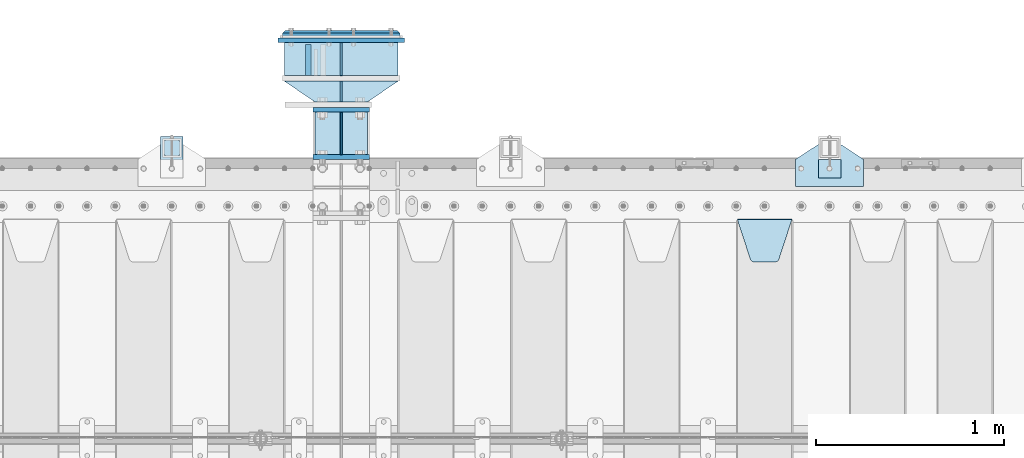
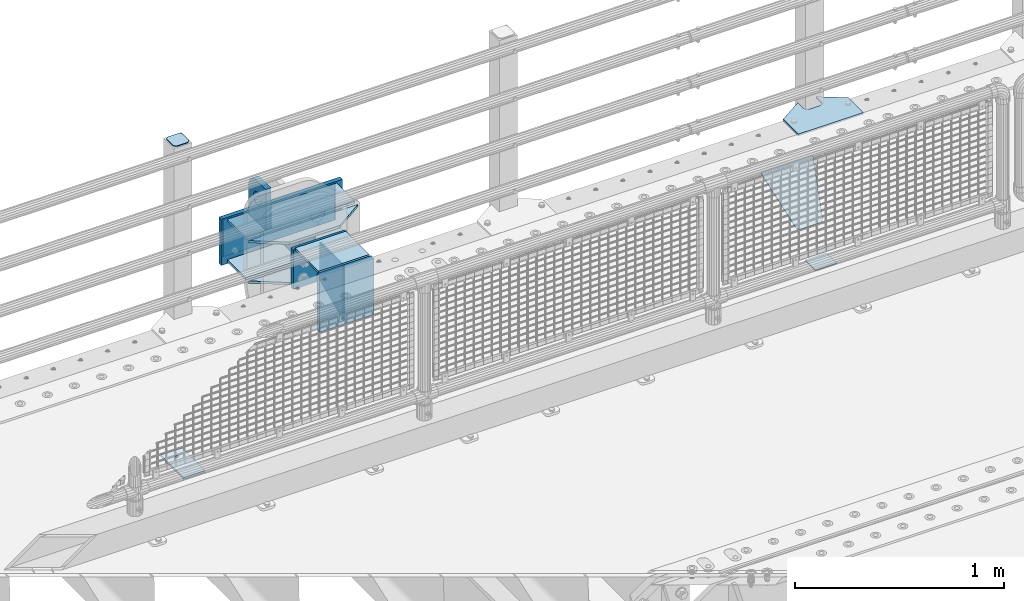
# One storey, part 222 of 247: 18 plates.
"""IFC2X3 building model written with IfcOpenShell, lengths in millimetres."""

from ifc_helpers import new_model, si_unit, frame, origin_with_axes, place, context, subcontext, project, spatial, faceted_brep, material, type_object, element, save


model = new_model("IFC2X3")

# Units and contexts
model_context = context("Model", 3, precision=1e-05, world=origin_with_axes())
body_context = subcontext(model_context, "Body", "Model", "MODEL_VIEW")
ifc_project = project(units=[si_unit("LENGTHUNIT", "METRE", prefix="MILLI"), si_unit("AREAUNIT", "SQUARE_METRE"), si_unit("VOLUMEUNIT", "CUBIC_METRE"), si_unit("MASSUNIT", "GRAM", prefix="KILO"), si_unit("TIMEUNIT", "SECOND"), si_unit("PLANEANGLEUNIT", "RADIAN"), si_unit("SOLIDANGLEUNIT", "STERADIAN"), si_unit("THERMODYNAMICTEMPERATUREUNIT", "DEGREE_CELSIUS"), si_unit("LUMINOUSINTENSITYUNIT", "LUMEN")], contexts=[model_context])

# Site, building, storey
site_placement = place(None, origin_with_axes())
site = spatial("IfcSite", under=ifc_project, at=site_placement, CompositionType="ELEMENT")
building_placement = place(site_placement, origin_with_axes())
building = spatial("IfcBuilding", under=site, at=building_placement, Name="Standard", CompositionType="ELEMENT")
storey_placement = place(building_placement, origin_with_axes())
storey = spatial("IfcBuildingStorey", under=building, at=storey_placement, Name="Undefined", CompositionType="ELEMENT", Elevation=0.0)

# Plates
ifc_material_1 = material(Name="STEEL/S355N")
plate_type_1 = type_object("IfcPlateType", PredefinedType="NOTDEFINED")
plate_1_placement = place(storey_placement, frame((12099.9999999856, 9162.50000001511, -340.000018222004), z_axis=(0.0, 0.0, 1.0), x_axis=(1.0, 0.0, 0.0)))
element("IfcPlate", 1, at=plate_1_placement, inside=storey, type_object=plate_type_1, material=ifc_material_1, context=body_context, shape_type="Brep", body=[
    faceted_brep([(0.0, -12.5, 0.0), (0.0, -12.5, 330.0), (0.0, 12.5, 330.0), (0.0, 12.5, 0.0), (300.0, -12.5, 330.0), (300.0, 12.5, 330.0), (300.0, -12.5, 0.0), (300.0, 12.5, 0.0)], [[[0, 1, 2, 3]], [[1, 4, 5, 2]], [[4, 6, 7, 5]], [[6, 0, 3, 7]], [[5, 7, 3, 2]], [[6, 4, 1, 0]]]),
])
plate_type_2 = type_object("IfcPlateType", PredefinedType="NOTDEFINED")
plate_2_placement = place(storey_placement, frame((12249.9999999856, 9175.00000001511, -336.000018222004), z_axis=(0.0, 1.0, 0.0), x_axis=(0.0, 0.0, 1.0)))
element("IfcPlate", 2, at=plate_2_placement, inside=storey, type_object=plate_type_2, material=ifc_material_1, context=body_context, shape_type="Brep", body=[
    faceted_brep([(9.04219632502645e-09, -5.00000000143385, -2.89173840428703e-09), (100.0, -5.0, 225.0), (100.0, 5.0, 225.0), (7.66340235713869e-09, 4.99999999856618, -2.89173840428703e-09), (322.0, -5.0, 225.0), (322.0, 5.0, 225.0), (322.0, -5.0, 0.0), (322.0, 5.0, 0.0)], [[[0, 1, 2, 3]], [[1, 4, 5, 2]], [[4, 6, 7, 5]], [[6, 0, 3, 7]], [[5, 7, 3, 2]], [[6, 4, 1, 0]]]),
])
plate_type_3 = type_object("IfcPlateType", PredefinedType="NOTDEFINED")
plate_3_placement = place(storey_placement, frame((12074.4999999856, 9595.00000001511, -1.8222003518531e-05), z_axis=(0.0, 1.0, 0.0), x_axis=(0.0, 0.0, 1.0)))
element("IfcPlate", 3, at=plate_3_placement, inside=storey, type_object=plate_type_3, material=ifc_material_1, context=body_context, shape_type="Brep", body=[
    faceted_brep([(125.840713002492, 15.0, 114.183542702918), (125.840713002492, -15.0, 114.183542702918), (113.837049096098, -15.0, 106.162950903903), (113.837049096098, 15.0, 106.162950903903), (105.816457297082, -15.0, 94.1592869975084), (105.816457297082, 15.0, 94.1592869975084), (103.0, -15.0, 80.0), (103.0, 15.0, 80.0), (105.816457297082, -15.0, 65.8407130024916), (105.816457297082, 15.0, 65.8407130024916), (113.837049096098, -15.0, 53.837049096097), (113.837049096098, 15.0, 53.837049096097), (125.840713002492, -15.0, 45.8164572970818), (125.840713002492, 15.0, 45.8164572970818), (140.0, -15.0, 43.0), (140.0, 15.0, 43.0), (154.159286997508, -15.0, 45.8164572970818), (154.159286997508, 15.0, 45.8164572970818), (166.162950903902, -15.0, 53.837049096097), (166.162950903902, 15.0, 53.837049096097), (174.183542702918, -15.0, 65.8407130024916), (174.183542702918, 15.0, 65.8407130024916), (177.0, -15.0, 80.0), (177.0, 15.0, 80.0), (174.183542702918, -15.0, 94.1592869975084), (174.183542702918, 15.0, 94.1592869975084), (166.162950903902, -15.0, 106.162950903903), (166.162950903902, 15.0, 106.162950903903), (154.159286997508, -15.0, 114.183542702918), (154.159286997508, 15.0, 114.183542702918), (140.0, -15.0, 117.0), (140.0, 15.0, 117.0), (0.0, -15.0, 165.0), (170.0, -15.0, 165.0), (170.0, 15.0, 165.0), (0.0, 15.0, 165.0), (188.117333157176, -15.0, 162.614807840235), (188.117333157176, 15.0, 162.614807840235), (205.0, -15.0, 155.621778264911), (205.0, 15.0, 155.621778264911), (219.497474683058, -15.0, 144.497474683058), (219.497474683058, 15.0, 144.497474683058), (230.621778264911, -15.0, 130.0), (230.621778264911, 15.0, 130.0), (237.614807840235, -15.0, 113.117333157177), (237.614807840235, 15.0, 113.117333157177), (240.0, -15.0, 95.0), (240.0, 15.0, 95.0), (240.0, -15.0, 0.0), (240.0, 15.0, 0.0), (0.0, -15.0, 0.0), (0.0, 15.0, 0.0)], [[[0, 1, 2, 3]], [[3, 2, 4, 5]], [[5, 4, 6, 7]], [[7, 6, 8, 9]], [[9, 8, 10, 11]], [[11, 10, 12, 13]], [[13, 12, 14, 15]], [[15, 14, 16, 17]], [[17, 16, 18, 19]], [[19, 18, 20, 21]], [[21, 20, 22, 23]], [[23, 22, 24, 25]], [[25, 24, 26, 27]], [[27, 26, 28, 29]], [[29, 28, 30, 31]], [[31, 30, 1, 0]], [[32, 33, 34, 35]], [[33, 36, 37, 34]], [[36, 38, 39, 37]], [[38, 40, 41, 39]], [[40, 42, 43, 41]], [[42, 44, 45, 43]], [[44, 46, 47, 45]], [[46, 48, 49, 47]], [[48, 50, 51, 49]], [[34, 37, 39, 41, 43, 45, 47, 49, 51, 35], [3, 5, 7, 9, 11, 13, 15, 17, 19, 21, 23, 25, 27, 29, 31, 0]], [[50, 32, 35, 51]], [[48, 46, 44, 42, 40, 38, 36, 33, 32, 50], [26, 24, 22, 20, 18, 16, 14, 12, 10, 8, 6, 4, 2, 1, 30, 28]]]),
])
plate_type_4 = type_object("IfcPlateType", PredefinedType="NOTDEFINED")
plate_4_placement = place(storey_placement, frame((14355.0, 8831.76776695594, -1.767766952965), z_axis=(0.0, -0.707106781186548, -0.707106781186547), x_axis=(1.0, 0.0, 0.0)))
element("IfcPlate", 4, at=plate_4_placement, inside=storey, type_object=plate_type_4, material=ifc_material_1, context=body_context, shape_type="Brep", body=[
    faceted_brep([(0.0, -2.49999999999909, 0.0), (69.345504679477, -2.5, 300.17173142483), (69.345504679477, 2.50000000000091, 300.171731424831), (0.0, 2.5, -9.09494701772928e-13), (70.9274061199576, -2.5, 304.897442415399), (70.9274061199576, 2.50000000000091, 304.8974424154), (73.3818627772307, -2.49999999999909, 309.234538108527), (73.3818627772307, 2.5, 309.234538108526), (76.6187032999551, -2.5, 313.023683126102), (76.6187032999551, 2.50000000000091, 313.023683126102), (80.5190132704993, -2.49999999999909, 316.125672595371), (80.5190132704993, 2.50000000000091, 316.125672595372), (84.9395038596849, -2.49999999999909, 318.426546230476), (84.9395038596849, 2.5, 318.426546230475), (89.7177759439219, -2.5, 319.841774983274), (89.7177759439219, 2.50000000000091, 319.841774983275), (94.678286292652, -2.5, 320.319366455077), (94.678286292652, 2.50000000000091, 320.319366455077), (195.321713707348, -2.5, 320.319366455077), (195.321713707348, 2.50000000000091, 320.319366455077), (200.282224056078, -2.5, 319.841774983274), (200.282224056078, 2.50000000000091, 319.841774983275), (205.060496140315, -2.5, 318.426546230475), (205.060496140315, 2.5, 318.426546230474), (209.480986729501, -2.49999999999818, 316.12567259537), (209.480986729501, 2.50000000000091, 316.12567259537), (213.381296700045, -2.5, 313.023683126101), (213.381296700045, 2.50000000000091, 313.023683126101), (216.618137222769, -2.5, 309.234538108525), (216.618137222769, 2.5, 309.234538108525), (219.072593880042, -2.49999999999909, 304.897442415398), (219.072593880042, 2.5, 304.897442415398), (220.654495320523, -2.5, 300.17173142483), (220.654495320523, 2.50000000000091, 300.171731424831), (290.0, -2.49999999999909, 0.0), (290.0, 2.5, -9.09494701772928e-13)], [[[0, 1, 2, 3]], [[1, 4, 5, 2]], [[4, 6, 7, 5]], [[6, 8, 9, 7]], [[8, 10, 11, 9]], [[10, 12, 13, 11]], [[12, 14, 15, 13]], [[14, 16, 17, 15]], [[16, 18, 19, 17]], [[18, 20, 21, 19]], [[20, 22, 23, 21]], [[22, 24, 25, 23]], [[24, 26, 27, 25]], [[26, 28, 29, 27]], [[28, 30, 31, 29]], [[30, 32, 33, 31]], [[32, 34, 35, 33]], [[34, 0, 3, 35]], [[5, 7, 9, 11, 13, 15, 17, 19, 21, 23, 25, 27, 29, 31, 33, 35, 3, 2]], [[34, 32, 30, 28, 26, 24, 22, 20, 18, 16, 14, 12, 10, 8, 6, 4, 1, 0]]]),
])
ifc_material_2 = material(Name="STEEL/S355J2")
plate_type_5 = type_object("IfcPlateType", PredefinedType="NOTDEFINED")
plate_5_placement = place(storey_placement, frame((14665.0, 9005.0, 5.00000000004911), z_axis=(0.0, 1.0, 0.0), x_axis=(1.0, 0.0, 0.0)))
element("IfcPlate", 5, at=plate_5_placement, inside=storey, type_object=plate_type_5, material=ifc_material_2, context=body_context, shape_type="Brep", body=[
    faceted_brep([(9.04219632502645e-09, -5.00000000143385, -2.89173840428703e-09), (2.31396552408114e-06, -5.0, 145.0), (2.31396552408114e-06, 5.0, 145.0), (7.66340235713869e-09, 4.99999999856618, -2.89173840428703e-09), (130.0, -5.0, 230.0), (130.0, 5.0, 230.0), (130.0, -5.0, 180.0), (130.0, 5.0, 180.0), (130.48036798992, -5.0, 175.122741949597), (130.48036798992, 5.0, 175.122741949597), (131.903011687218, -5.0, 170.432914190873), (131.903011687218, 5.0, 170.432914190873), (134.213259692437, -5.0, 166.11074417451), (134.213259692437, 5.0, 166.11074417451), (137.322330470337, -5.0, 162.322330470337), (137.322330470337, 5.0, 162.322330470337), (141.11074417451, -5.0, 159.213259692437), (141.11074417451, 5.0, 159.213259692437), (145.432914190873, -5.0, 156.903011687218), (145.432914190873, 5.0, 156.903011687218), (150.122741949597, -5.0, 155.48036798992), (150.122741949597, 5.0, 155.48036798992), (155.0, -5.0, 155.0), (155.0, 5.0, 155.0), (205.0, -5.0, 155.0), (205.0, 5.0, 155.0), (209.877258050403, -5.0, 155.48036798992), (209.877258050403, 5.0, 155.48036798992), (214.567085809127, -5.0, 156.903011687218), (214.567085809127, 5.0, 156.903011687218), (218.88925582549, -5.0, 159.213259692437), (218.88925582549, 5.0, 159.213259692437), (222.677669529663, -5.0, 162.322330470337), (222.677669529663, 5.0, 162.322330470337), (225.786740307563, -5.0, 166.11074417451), (225.786740307563, 5.0, 166.11074417451), (228.096988312782, -5.0, 170.432914190873), (228.096988312782, 5.0, 170.432914190873), (229.51963201008, -5.0, 175.122741949597), (229.51963201008, 5.0, 175.122741949597), (230.0, -5.0, 180.0), (230.0, 5.0, 180.0), (230.0, -5.0, 230.0), (230.0, 5.0, 230.0), (360.0, -5.0, 145.0), (360.0, 5.0, 145.0), (360.0, -5.0, -7.27595761418343e-12), (360.0, 5.0, -7.27595761418343e-12)], [[[0, 1, 2, 3]], [[1, 4, 5, 2]], [[4, 6, 7, 5]], [[6, 8, 9, 7]], [[8, 10, 11, 9]], [[10, 12, 13, 11]], [[12, 14, 15, 13]], [[14, 16, 17, 15]], [[16, 18, 19, 17]], [[18, 20, 21, 19]], [[20, 22, 23, 21]], [[22, 24, 25, 23]], [[24, 26, 27, 25]], [[26, 28, 29, 27]], [[28, 30, 31, 29]], [[30, 32, 33, 31]], [[32, 34, 35, 33]], [[34, 36, 37, 35]], [[36, 38, 39, 37]], [[38, 40, 41, 39]], [[40, 42, 43, 41]], [[42, 44, 45, 43]], [[44, 46, 47, 45]], [[46, 0, 3, 47]], [[5, 7, 9, 11, 13, 15, 17, 19, 21, 23, 25, 27, 29, 31, 33, 35, 37, 39, 41, 43, 45, 47, 3, 2]], [[46, 44, 42, 40, 38, 36, 34, 32, 30, 28, 26, 24, 22, 20, 18, 16, 14, 12, 10, 8, 6, 4, 1, 0]]]),
])
plate_type_6 = type_object("IfcPlateType", PredefinedType="NOTDEFINED")
plate_6_placement = place(storey_placement, frame((11290.0000000001, 9050.00000000021, -850.000000000002), z_axis=(0.0, 1.0, 0.0), x_axis=(1.0, 0.0, 0.0)))
element("IfcPlate", 6, at=plate_6_placement, inside=storey, type_object=plate_type_6, material=ifc_material_2, context=body_context, shape_type="Brep", body=[
    faceted_brep([(66.3639610305399, -5.0, 163.636038969113), (66.3639610305399, 5.0, 163.636038969113), (59.9999999998618, 5.0, 160.999999999791), (59.9999999998618, -5.0, 160.999999999791), (53.6360389691836, 5.0, 163.636038969113), (53.6360389691836, -5.0, 163.636038969113), (50.9999999998618, 5.0, 169.999999999791), (50.9999999998618, -5.0, 169.999999999791), (53.6360389691836, 5.0, 176.363961030469), (53.6360389691836, -5.0, 176.363961030469), (59.9999999998618, 5.0, 178.999999999791), (59.9999999998618, -5.0, 178.999999999791), (66.3639610305399, 5.0, 176.363961030469), (66.3639610305399, -5.0, 176.363961030469), (68.9999999998618, 5.0, 169.999999999791), (68.9999999998618, -5.0, 169.999999999791), (120.0, -5.0, 0.0), (120.0, -5.0, 220.0), (0.0, -5.0, 220.0), (9.04219632502645e-09, -5.00000000143385, -2.89173840428703e-09), (7.66340235713869e-09, 4.99999999856618, -2.89173840428703e-09), (120.0, 5.0, 0.0), (120.0, 5.0, 220.0), (0.0, 5.0, 220.0)], [[[0, 1, 2, 3]], [[3, 2, 4, 5]], [[5, 4, 6, 7]], [[7, 6, 8, 9]], [[9, 8, 10, 11]], [[11, 10, 12, 13]], [[13, 12, 14, 15]], [[15, 14, 1, 0]], [[16, 17, 18, 19], [3, 5, 7, 9, 11, 13, 15, 0]], [[16, 19, 20, 21]], [[17, 16, 21, 22]], [[18, 17, 22, 23]], [[19, 18, 23, 20]], [[22, 21, 20, 23], [10, 8, 6, 4, 2, 1, 14, 12]]]),
])
plate_type_7 = type_object("IfcPlateType", PredefinedType="NOTDEFINED")
plate_7_placement = place(storey_placement, frame((11394.0000000001, 9166.00000000021, 1012.50000000001), z_axis=(0.0, 1.0, 0.0), x_axis=(-1.0, 0.0, 0.0)))
element("IfcPlate", 7, at=plate_7_placement, inside=storey, type_object=plate_type_7, material=ifc_material_2, context=body_context, shape_type="Brep", body=[
    faceted_brep([(0.0, -2.5, 19.0), (0.0, -2.5, 69.0), (0.0, 2.5, 69.0), (0.0, 2.5, 19.0), (0.476369668545885, -2.5, 73.2278977451697), (0.476369668545885, 2.5, 73.2278977451697), (1.88159150985484, -2.5, 77.2437910432327), (1.88159150985484, 2.5, 77.2437910432327), (4.14520183310742, -2.5, 80.8463062353167), (4.14520183310742, 2.5, 80.8463062353167), (7.15369376468334, -2.5, 83.8547981668926), (7.15369376468334, 2.5, 83.8547981668926), (10.7562089567673, -2.5, 86.1184084901452), (10.7562089567673, 2.5, 86.1184084901452), (14.7721022548303, -2.5, 87.5236303314541), (14.7721022548303, 2.5, 87.5236303314541), (19.0, -2.5, 88.0), (19.0, 2.5, 88.0), (69.0, -2.5, 88.0), (69.0, 2.5, 88.0), (73.2278977451697, -2.5, 87.5236303314541), (73.2278977451697, 2.5, 87.5236303314541), (77.2437910432327, -2.5, 86.1184084901452), (77.2437910432327, 2.5, 86.1184084901452), (80.8463062353167, -2.5, 83.8547981668926), (80.8463062353167, 2.5, 83.8547981668926), (83.8547981668926, -2.5, 80.8463062353167), (83.8547981668926, 2.5, 80.8463062353167), (86.1184084901452, -2.5, 77.2437910432327), (86.1184084901452, 2.5, 77.2437910432327), (87.5236303314541, -2.5, 73.2278977451697), (87.5236303314541, 2.5, 73.2278977451697), (88.0, -2.5, 69.0), (88.0, 2.5, 69.0), (88.0, -2.5, 19.0), (88.0, 2.5, 19.0), (87.5236303314541, -2.5, 14.7721022548303), (87.5236303314541, 2.5, 14.7721022548303), (86.1184084901452, -2.5, 10.7562089567673), (86.1184084901452, 2.5, 10.7562089567673), (83.8547981668926, -2.5, 7.15369376468334), (83.8547981668926, 2.5, 7.15369376468334), (80.8463062353167, -2.5, 4.14520183310742), (80.8463062353167, 2.5, 4.14520183310742), (77.2437910432345, -2.5, 1.88159150985484), (77.2437910432345, 2.5, 1.88159150985484), (73.2278977451697, -2.5, 0.476369668545885), (73.2278977451697, 2.5, 0.476369668545885), (69.0, -2.5, 0.0), (69.0, 2.5, 0.0), (19.0, -2.5, 0.0), (19.0, 2.5, 0.0), (14.7721022548303, -2.5, 0.476369668545885), (14.7721022548303, 2.5, 0.476369668545885), (10.7562089567673, -2.5, 1.88159150985484), (10.7562089567673, 2.5, 1.88159150985484), (7.15369376468334, -2.5, 4.14520183310742), (7.15369376468334, 2.5, 4.14520183310742), (4.14520183310742, -2.5, 7.15369376468334), (4.14520183310742, 2.5, 7.15369376468334), (1.88159150985484, -2.5, 10.7562089567673), (1.88159150985484, 2.5, 10.7562089567673), (0.476369668545885, -2.5, 14.7721022548303), (0.476369668545885, 2.5, 14.7721022548303)], [[[0, 1, 2, 3]], [[1, 4, 5, 2]], [[4, 6, 7, 5]], [[6, 8, 9, 7]], [[8, 10, 11, 9]], [[10, 12, 13, 11]], [[12, 14, 15, 13]], [[14, 16, 17, 15]], [[16, 18, 19, 17]], [[18, 20, 21, 19]], [[20, 22, 23, 21]], [[22, 24, 25, 23]], [[24, 26, 27, 25]], [[26, 28, 29, 27]], [[28, 30, 31, 29]], [[30, 32, 33, 31]], [[32, 34, 35, 33]], [[34, 36, 37, 35]], [[36, 38, 39, 37]], [[38, 40, 41, 39]], [[40, 42, 43, 41]], [[42, 44, 45, 43]], [[44, 46, 47, 45]], [[46, 48, 49, 47]], [[48, 50, 51, 49]], [[50, 52, 53, 51]], [[52, 54, 55, 53]], [[54, 56, 57, 55]], [[56, 58, 59, 57]], [[58, 60, 61, 59]], [[60, 62, 63, 61]], [[62, 0, 3, 63]], [[5, 7, 9, 11, 13, 15, 17, 19, 21, 23, 25, 27, 29, 31, 33, 35, 37, 39, 41, 43, 45, 47, 49, 51, 53, 55, 57, 59, 61, 63, 3, 2]], [[62, 60, 58, 56, 54, 52, 50, 48, 46, 44, 42, 40, 38, 36, 34, 32, 30, 28, 26, 24, 22, 20, 18, 16, 14, 12, 10, 8, 6, 4, 1, 0]]]),
])
plate_type_8 = type_object("IfcPlateType", PredefinedType="NOTDEFINED")
plate_8_placement = place(storey_placement, frame((14785.0000000001, 9050.00000000021, -857.500000000002), z_axis=(0.0, 1.0, 0.0), x_axis=(1.0, 0.0, 0.0)))
element("IfcPlate", 8, at=plate_8_placement, inside=storey, type_object=plate_type_8, material=ifc_material_2, context=body_context, shape_type="Brep", body=[
    faceted_brep([(0.0, -2.49999999999909, 0.0), (0.0, -2.5, 100.0), (0.0, 2.5, 100.0), (0.0, 2.5, -9.09494701772928e-13), (120.0, -2.5, 100.0), (120.0, 2.5, 100.0), (120.0, -2.5, 0.0), (120.0, 2.5, 0.0)], [[[0, 1, 2, 3]], [[1, 4, 5, 2]], [[4, 6, 7, 5]], [[6, 0, 3, 7]], [[5, 7, 3, 2]], [[6, 4, 1, 0]]]),
])
plate_type_9 = type_object("IfcPlateType", PredefinedType="NOTDEFINED")
plate_9_placement = place(storey_placement, frame((12249.9999999856, 9770.00000001511, -14.0000182220035), z_axis=(0.0, 0.0, -1.0), x_axis=(0.0, -0.999999999999548, -9.5100000000016e-07)))
element("IfcPlate", 9, at=plate_9_placement, inside=storey, type_object=plate_type_9, material=ifc_material_1, context=body_context, shape_type="Brep", body=[
    faceted_brep([(9.04219632502645e-09, -5.00000000143385, -2.89173840428703e-09), (0.0, -5.0, 222.0), (0.0, 5.0, 222.0), (7.66340235713869e-09, 4.99999999856618, -2.89173840428703e-09), (175.0, -5.0, 222.0), (175.0, 5.0, 222.0), (175.0, -5.0, 0.0), (175.0, 5.0, 0.0)], [[[0, 1, 2, 3]], [[1, 4, 5, 2]], [[4, 6, 7, 5]], [[6, 0, 3, 7]], [[5, 7, 3, 2]], [[6, 4, 1, 0]]]),
])
plate_type_10 = type_object("IfcPlateType", PredefinedType="NOTDEFINED")
plate_10_placement = place(storey_placement, frame((12249.9999999856, 9565.00000001511, -14.0000182220035), z_axis=(0.0, 0.0, -1.0), x_axis=(0.0, -0.999999999999548, -9.5100000000016e-07)))
element("IfcPlate", 10, at=plate_10_placement, inside=storey, type_object=plate_type_10, material=ifc_material_1, context=body_context, shape_type="Brep", body=[
    faceted_brep([(9.04219632502645e-09, -5.00000000143385, -2.89173840428703e-09), (0.0, -5.0, 222.0), (0.0, 5.0, 222.0), (7.66340235713869e-09, 4.99999999856618, -2.89173840428703e-09), (110.0, -5.0, 222.0), (110.0, 5.0, 222.0), (110.0, -5.0, 0.0), (110.0, 5.0, 0.0)], [[[0, 1, 2, 3]], [[1, 4, 5, 2]], [[4, 6, 7, 5]], [[6, 0, 3, 7]], [[5, 7, 3, 2]], [[6, 4, 1, 0]]]),
])
ifc_material_3 = material()
plate_type_11 = type_object("IfcPlateType", PredefinedType="NOTDEFINED")
for number, where, z_axis, x_axis in (
    (11, (12552.4999999856, 9595.00000001511, -7.00001822200352), (0.0, 1.0, 0.0), (-1.0, 0.0, 0.0)),
    (12, (12552.4999999856, 9595.00000001511, -243.000018222004), (0.0, 1.0, 0.0), (-1.0, 0.0, 0.0)),
):
    element("IfcPlate", number, at=place(storey_placement, frame(where, z_axis=z_axis, x_axis=x_axis)), inside=storey, type_object=plate_type_11, material=ifc_material_3, context=body_context, shape_type="Brep", body=[
        faceted_brep([(0.0, -7.0, 0.0), (0.0, -7.0, 175.0), (0.0, 7.0, 175.0), (0.0, 7.0, 0.0), (605.0, -7.0, 175.0), (605.0, 7.0, 175.0), (605.0, -7.0, 0.0), (605.0, 7.0, 0.0)], [[[0, 1, 2, 3]], [[1, 4, 5, 2]], [[4, 6, 7, 5]], [[6, 0, 3, 7]], [[5, 7, 3, 2]], [[6, 4, 1, 0]]]),
    ])
plate_type_12 = type_object("IfcPlateType", PredefinedType="NOTDEFINED")
for number, where, z_axis, x_axis in (
    (13, (12552.4999999856, 9565.00000001511, -7.00001822200352), (-0.560566412034006, 0.828109472050236, 0.0), (-0.828109472050237, -0.560566412034006, 0.0)),
    (14, (12552.4999999856, 9565.00000001511, -243.000018222004), (-0.560566412034006, 0.828109472050236, 0.0), (-0.828109472050237, -0.560566412034006, 0.0)),
):
    element("IfcPlate", number, at=place(storey_placement, frame(where, z_axis=z_axis, x_axis=x_axis)), inside=storey, type_object=plate_type_12, material=ifc_material_1, context=body_context, shape_type="Brep", body=[
        faceted_brep([(0.0, -7.0, 0.0), (501.006225585938, -7.0, 339.142669677734), (501.006225585938, 7.0, 339.142669677734), (0.0, 7.0, 0.0), (428.100738525391, -7.0, 156.958602905274), (428.100738525391, 7.0, 156.958602905274), (196.230087280275, -7.0, -3.64934749086387e-11), (196.230087280275, 7.0, -3.64934749086387e-11)], [[[0, 1, 2, 3]], [[1, 4, 5, 2]], [[4, 6, 7, 5]], [[6, 0, 3, 7]], [[5, 7, 3, 2]], [[6, 4, 1, 0]]]),
    ])
plate_type_13 = type_object("IfcPlateType", PredefinedType="NOTDEFINED")
plate_11_placement = place(storey_placement, frame((12584.9999999856, 9782.50000001511, 9.99998177799648), z_axis=(0.0, 0.0, -1.0), x_axis=(-1.0, 0.0, 0.0)))
element("IfcPlate", 15, at=plate_11_placement, inside=storey, type_object=plate_type_13, material=ifc_material_1, context=body_context, shape_type="Brep", body=[
    faceted_brep([(0.0, -12.5, 0.0), (0.0, -12.5, 270.0), (0.0, 12.5, 270.0), (0.0, 12.5, 0.0), (670.0, -12.5, 270.0), (670.0, 12.5, 270.0), (670.0, -12.5, 0.0), (670.0, 12.5, 0.0)], [[[0, 1, 2, 3]], [[1, 4, 5, 2]], [[4, 6, 7, 5]], [[6, 0, 3, 7]], [[5, 7, 3, 2]], [[6, 4, 1, 0]]]),
])
plate_type_14 = type_object("IfcPlateType", PredefinedType="NOTDEFINED")
plate_12_placement = place(storey_placement, frame((12099.9999999856, 9412.50000001511, -240.000018222004), z_axis=(0.0, 0.0, 1.0), x_axis=(1.0, 0.0, 0.0)))
element("IfcPlate", 16, at=plate_12_placement, inside=storey, type_object=plate_type_14, material=ifc_material_1, context=body_context, shape_type="Brep", body=[
    faceted_brep([(0.0, -12.5, 0.0), (0.0, -12.5, 230.0), (0.0, 12.5, 230.0), (0.0, 12.5, 0.0), (300.0, -12.5, 230.0), (300.0, 12.5, 230.0), (300.0, -12.5, 0.0), (300.0, 12.5, 0.0)], [[[0, 1, 2, 3]], [[1, 4, 5, 2]], [[4, 6, 7, 5]], [[6, 0, 3, 7]], [[5, 7, 3, 2]], [[6, 4, 1, 0]]]),
])
ifc_material_4 = material()
plate_type_15 = type_object("IfcPlateType", PredefinedType="NOTDEFINED")
plate_13_placement = place(storey_placement, frame((12562.4999999856, 9815.00000001511, -12.5000182220035), z_axis=(0.0, 0.0, -1.0), x_axis=(-1.0, 0.0, 0.0)))
element("IfcPlate", 17, at=plate_13_placement, inside=storey, type_object=plate_type_15, material=ifc_material_4, context=body_context, shape_type="Brep", body=[
    faceted_brep([(0.0, -15.0, 0.0), (5.0, -20.0, 5.0), (5.0, -20.0, 220.0), (0.0, -15.0, 225.0), (625.0, -15.0, 0.0), (620.0, -20.0, 5.0), (620.0, -20.0, 220.0), (625.0, -15.0, 225.0), (15.0, 20.0, 15.0), (7.66340235713869e-09, 4.99999999856618, -2.89173840428703e-09), (0.0, 5.0, 225.0), (15.0, 20.0, 210.0), (625.0, 5.0, 225.0), (610.0, 20.0, 210.0), (625.0, 5.0, 0.0), (610.0, 20.0, 15.0), (64.8205080756888, -5.0, 37.4999999999998), (57.5, -5.0, 30.179491924311), (47.5, -5.0, 27.4999999999998), (37.5, -5.0, 30.179491924311), (30.1794919243112, -5.0, 37.4999999999998), (27.5, -5.0, 47.4999999999998), (30.1794919243112, -5.0, 57.4999999999998), (37.5, -5.0, 64.8205080756885), (47.5, -5.0, 67.4999999999998), (57.5, -5.0, 64.8205080756886), (64.8205080756888, -5.0, 57.4999999999998), (67.5, -5.0, 47.4999999999998), (37.5, 20.0, 64.8205080756885), (30.1794919243112, 20.0, 57.4999999999998), (47.5, 20.0, 67.4999999999998), (57.5, 20.0, 64.8205080756886), (64.8205080756888, 20.0, 57.4999999999998), (67.5, 20.0, 47.4999999999998), (64.8205080756888, 20.0, 37.4999999999998), (57.5, 20.0, 30.179491924311), (47.5, 20.0, 27.4999999999998), (37.5, 20.0, 30.179491924311), (30.1794919243112, 20.0, 37.4999999999998), (27.5, 20.0, 47.4999999999998), (394.820508075689, -5.0, 37.4999999999998), (387.5, -5.0, 30.179491924311), (377.5, -5.0, 27.4999999999998), (367.5, -5.0, 30.179491924311), (360.179491924311, -5.0, 37.4999999999998), (357.5, -5.0, 47.4999999999998), (360.179491924311, -5.0, 57.4999999999998), (367.5, -5.0, 64.8205080756885), (377.5, -5.0, 67.4999999999998), (387.5, -5.0, 64.8205080756886), (394.820508075689, -5.0, 57.4999999999998), (397.5, -5.0, 47.4999999999998), (360.179491924311, 20.0, 57.4999999999998), (357.5, 20.0, 47.4999999999998), (367.5, 20.0, 64.8205080756885), (377.5, 20.0, 67.4999999999998), (387.5, 20.0, 64.8205080756886), (394.820508075689, 20.0, 57.4999999999998), (397.5, 20.0, 47.4999999999998), (394.820508075689, 20.0, 37.4999999999998), (387.5, 20.0, 30.179491924311), (377.5, 20.0, 27.4999999999998), (367.5, 20.0, 30.179491924311), (360.179491924311, 20.0, 37.4999999999998), (394.820508075689, -5.0, 167.5), (387.5, -5.0, 160.179491924311), (377.5, -5.0, 157.5), (367.5, -5.0, 160.179491924311), (360.179491924311, -5.0, 167.5), (357.5, -5.0, 177.5), (360.179491924311, -5.0, 187.5), (367.5, -5.0, 194.820508075689), (377.5, -5.0, 197.5), (387.5, -5.0, 194.820508075689), (394.820508075689, -5.0, 187.5), (397.5, -5.0, 177.5), (360.179491924311, 20.0, 187.5), (357.5, 20.0, 177.5), (367.5, 20.0, 194.820508075689), (377.5, 20.0, 197.5), (387.5, 20.0, 194.820508075689), (394.820508075689, 20.0, 187.5), (397.5, 20.0, 177.5), (394.820508075689, 20.0, 167.5), (387.5, 20.0, 160.179491924311), (377.5, 20.0, 157.5), (367.5, 20.0, 160.179491924311), (360.179491924311, 20.0, 167.5), (594.820508075689, -5.0, 167.5), (587.5, -5.0, 160.179491924311), (577.5, -5.0, 157.5), (567.5, -5.0, 160.179491924311), (560.179491924311, -5.0, 167.5), (557.5, -5.0, 177.5), (560.179491924311, -5.0, 187.5), (567.5, -5.0, 194.820508075689), (577.5, -5.0, 197.5), (587.5, -5.0, 194.820508075689), (594.820508075689, -5.0, 187.5), (597.5, -5.0, 177.5), (560.179491924311, 20.0, 187.5), (557.5, 20.0, 177.5), (567.5, 20.0, 194.820508075689), (577.5, 20.0, 197.5), (587.5, 20.0, 194.820508075689), (594.820508075689, 20.0, 187.5), (597.5, 20.0, 177.5), (594.820508075689, 20.0, 167.5), (587.5, 20.0, 160.179491924311), (577.5, 20.0, 157.5), (567.5, 20.0, 160.179491924311), (560.179491924311, 20.0, 167.5), (264.820508075689, -5.0, 37.4999999999998), (257.5, -5.0, 30.179491924311), (247.5, -5.0, 27.4999999999998), (237.5, -5.0, 30.179491924311), (230.179491924311, -5.0, 37.4999999999998), (227.5, -5.0, 47.4999999999998), (230.179491924311, -5.0, 57.4999999999998), (237.5, -5.0, 64.8205080756885), (247.5, -5.0, 67.4999999999998), (257.5, -5.0, 64.8205080756886), (264.820508075689, -5.0, 57.4999999999998), (267.5, -5.0, 47.4999999999998), (230.179491924311, 20.0, 57.4999999999998), (227.5, 20.0, 47.4999999999998), (237.5, 20.0, 64.8205080756885), (247.5, 20.0, 67.4999999999998), (257.5, 20.0, 64.8205080756886), (264.820508075689, 20.0, 57.4999999999998), (267.5, 20.0, 47.4999999999998), (264.820508075689, 20.0, 37.4999999999998), (257.5, 20.0, 30.179491924311), (247.5, 20.0, 27.4999999999998), (237.5, 20.0, 30.179491924311), (230.179491924311, 20.0, 37.4999999999998), (64.8205080756888, -5.0, 167.5), (57.5, -5.0, 160.179491924311), (47.5, -5.0, 157.5), (37.5, -5.0, 160.179491924311), (30.1794919243112, -5.0, 167.5), (27.5, -5.0, 177.5), (30.1794919243112, -5.0, 187.5), (37.5, -5.0, 194.820508075689), (47.5, -5.0, 197.5), (57.5, -5.0, 194.820508075689), (64.8205080756888, -5.0, 187.5), (67.5, -5.0, 177.5), (30.1794919243112, 20.0, 187.5), (27.5, 20.0, 177.5), (37.5, 20.0, 194.820508075689), (47.5, 20.0, 197.5), (57.5, 20.0, 194.820508075689), (64.8205080756888, 20.0, 187.5), (67.5, 20.0, 177.5), (64.8205080756888, 20.0, 167.5), (57.5, 20.0, 160.179491924311), (47.5, 20.0, 157.5), (37.5, 20.0, 160.179491924311), (30.1794919243112, 20.0, 167.5), (264.820508075689, -5.0, 167.5), (257.5, -5.0, 160.179491924311), (247.5, -5.0, 157.5), (237.5, -5.0, 160.179491924311), (230.179491924311, -5.0, 167.5), (227.5, -5.0, 177.5), (230.179491924311, -5.0, 187.5), (237.5, -5.0, 194.820508075689), (247.5, -5.0, 197.5), (257.5, -5.0, 194.820508075689), (264.820508075689, -5.0, 187.5), (267.5, -5.0, 177.5), (230.179491924311, 20.0, 187.5), (227.5, 20.0, 177.5), (237.5, 20.0, 194.820508075689), (247.5, 20.0, 197.5), (257.5, 20.0, 194.820508075689), (264.820508075689, 20.0, 187.5), (267.5, 20.0, 177.5), (264.820508075689, 20.0, 167.5), (257.5, 20.0, 160.179491924311), (247.5, 20.0, 157.5), (237.5, 20.0, 160.179491924311), (230.179491924311, 20.0, 167.5), (594.820508075689, -5.0, 37.4999999999998), (587.5, -5.0, 30.179491924311), (577.5, -5.0, 27.4999999999998), (567.5, -5.0, 30.179491924311), (560.179491924311, -5.0, 37.4999999999998), (557.5, -5.0, 47.4999999999998), (560.179491924311, -5.0, 57.4999999999998), (567.5, -5.0, 64.8205080756885), (577.5, -5.0, 67.4999999999998), (587.5, -5.0, 64.8205080756886), (594.820508075689, -5.0, 57.4999999999998), (597.5, -5.0, 47.4999999999998), (560.179491924311, 20.0, 57.4999999999998), (557.5, 20.0, 47.4999999999998), (567.5, 20.0, 64.8205080756885), (577.5, 20.0, 67.4999999999998), (587.5, 20.0, 64.8205080756886), (594.820508075689, 20.0, 57.4999999999998), (597.5, 20.0, 47.4999999999998), (594.820508075689, 20.0, 37.4999999999998), (587.5, 20.0, 30.179491924311), (577.5, 20.0, 27.4999999999998), (567.5, 20.0, 30.179491924311), (560.179491924311, 20.0, 37.4999999999998)], [[[0, 1, 2, 3]], [[4, 5, 1, 0]], [[6, 7, 3, 2]], [[7, 6, 5, 4]], [[8, 9, 10, 11]], [[12, 13, 11, 10]], [[14, 15, 13, 12]], [[15, 14, 9, 8]], [[16, 17, 18, 19, 20, 21, 22, 23, 24, 25, 26, 27]], [[28, 23, 22, 29]], [[30, 24, 23, 28]], [[31, 25, 24, 30]], [[32, 26, 25, 31]], [[33, 27, 26, 32]], [[34, 16, 27, 33]], [[35, 17, 16, 34]], [[36, 18, 17, 35]], [[37, 19, 18, 36]], [[38, 20, 19, 37]], [[39, 21, 20, 38]], [[29, 22, 21, 39]], [[5, 6, 2, 1]], [[9, 14, 4, 0]], [[14, 12, 7, 4]], [[12, 10, 3, 7]], [[10, 9, 0, 3]], [[40, 41, 42, 43, 44, 45, 46, 47, 48, 49, 50, 51]], [[52, 46, 45, 53]], [[54, 47, 46, 52]], [[55, 48, 47, 54]], [[56, 49, 48, 55]], [[57, 50, 49, 56]], [[58, 51, 50, 57]], [[59, 40, 51, 58]], [[60, 41, 40, 59]], [[61, 42, 41, 60]], [[62, 43, 42, 61]], [[63, 44, 43, 62]], [[53, 45, 44, 63]], [[64, 65, 66, 67, 68, 69, 70, 71, 72, 73, 74, 75]], [[76, 70, 69, 77]], [[78, 71, 70, 76]], [[79, 72, 71, 78]], [[80, 73, 72, 79]], [[81, 74, 73, 80]], [[82, 75, 74, 81]], [[83, 64, 75, 82]], [[84, 65, 64, 83]], [[85, 66, 65, 84]], [[86, 67, 66, 85]], [[87, 68, 67, 86]], [[77, 69, 68, 87]], [[88, 89, 90, 91, 92, 93, 94, 95, 96, 97, 98, 99]], [[100, 94, 93, 101]], [[102, 95, 94, 100]], [[103, 96, 95, 102]], [[104, 97, 96, 103]], [[105, 98, 97, 104]], [[106, 99, 98, 105]], [[107, 88, 99, 106]], [[108, 89, 88, 107]], [[109, 90, 89, 108]], [[110, 91, 90, 109]], [[111, 92, 91, 110]], [[101, 93, 92, 111]], [[112, 113, 114, 115, 116, 117, 118, 119, 120, 121, 122, 123]], [[124, 118, 117, 125]], [[126, 119, 118, 124]], [[127, 120, 119, 126]], [[128, 121, 120, 127]], [[129, 122, 121, 128]], [[130, 123, 122, 129]], [[131, 112, 123, 130]], [[132, 113, 112, 131]], [[133, 114, 113, 132]], [[134, 115, 114, 133]], [[135, 116, 115, 134]], [[125, 117, 116, 135]], [[136, 137, 138, 139, 140, 141, 142, 143, 144, 145, 146, 147]], [[148, 142, 141, 149]], [[150, 143, 142, 148]], [[151, 144, 143, 150]], [[152, 145, 144, 151]], [[153, 146, 145, 152]], [[154, 147, 146, 153]], [[155, 136, 147, 154]], [[156, 137, 136, 155]], [[157, 138, 137, 156]], [[158, 139, 138, 157]], [[159, 140, 139, 158]], [[149, 141, 140, 159]], [[160, 161, 162, 163, 164, 165, 166, 167, 168, 169, 170, 171]], [[172, 166, 165, 173]], [[174, 167, 166, 172]], [[175, 168, 167, 174]], [[176, 169, 168, 175]], [[177, 170, 169, 176]], [[178, 171, 170, 177]], [[179, 160, 171, 178]], [[180, 161, 160, 179]], [[181, 162, 161, 180]], [[182, 163, 162, 181]], [[183, 164, 163, 182]], [[173, 165, 164, 183]], [[184, 185, 186, 187, 188, 189, 190, 191, 192, 193, 194, 195]], [[196, 190, 189, 197]], [[198, 191, 190, 196]], [[199, 192, 191, 198]], [[200, 193, 192, 199]], [[201, 194, 193, 200]], [[202, 195, 194, 201]], [[203, 184, 195, 202]], [[204, 185, 184, 203]], [[205, 186, 185, 204]], [[206, 187, 186, 205]], [[207, 188, 187, 206]], [[197, 189, 188, 207]], [[13, 15, 8, 11], [37, 36, 35, 34, 33, 32, 31, 30, 28, 29, 39, 38], [206, 205, 204, 203, 202, 201, 200, 199, 198, 196, 197, 207], [182, 181, 180, 179, 178, 177, 176, 175, 174, 172, 173, 183], [158, 157, 156, 155, 154, 153, 152, 151, 150, 148, 149, 159], [134, 133, 132, 131, 130, 129, 128, 127, 126, 124, 125, 135], [110, 109, 108, 107, 106, 105, 104, 103, 102, 100, 101, 111], [86, 85, 84, 83, 82, 81, 80, 79, 78, 76, 77, 87], [62, 61, 60, 59, 58, 57, 56, 55, 54, 52, 53, 63]]]),
])
plate_type_16 = type_object("IfcPlateType", PredefinedType="NOTDEFINED")
plate_14_placement = place(storey_placement, frame((12109.9999999856, 9175.00000001511, -7.00001822200352), z_axis=(0.0, 1.0, 0.0), x_axis=(1.0, 0.0, 0.0)))
element("IfcPlate", 18, at=plate_14_placement, inside=storey, type_object=plate_type_16, material=ifc_material_1, context=body_context, shape_type="Brep", body=[
    faceted_brep([(0.0, -7.0, 0.0), (0.0, -7.0, 225.0), (0.0, 7.0, 225.0), (0.0, 7.0, 0.0), (280.0, -7.0, 225.0), (280.0, 7.0, 225.0), (280.0, -7.0, 0.0), (280.0, 7.0, 0.0)], [[[0, 1, 2, 3]], [[1, 4, 5, 2]], [[4, 6, 7, 5]], [[6, 0, 3, 7]], [[5, 7, 3, 2]], [[6, 4, 1, 0]]]),
])

save(model, "model.ifc")
